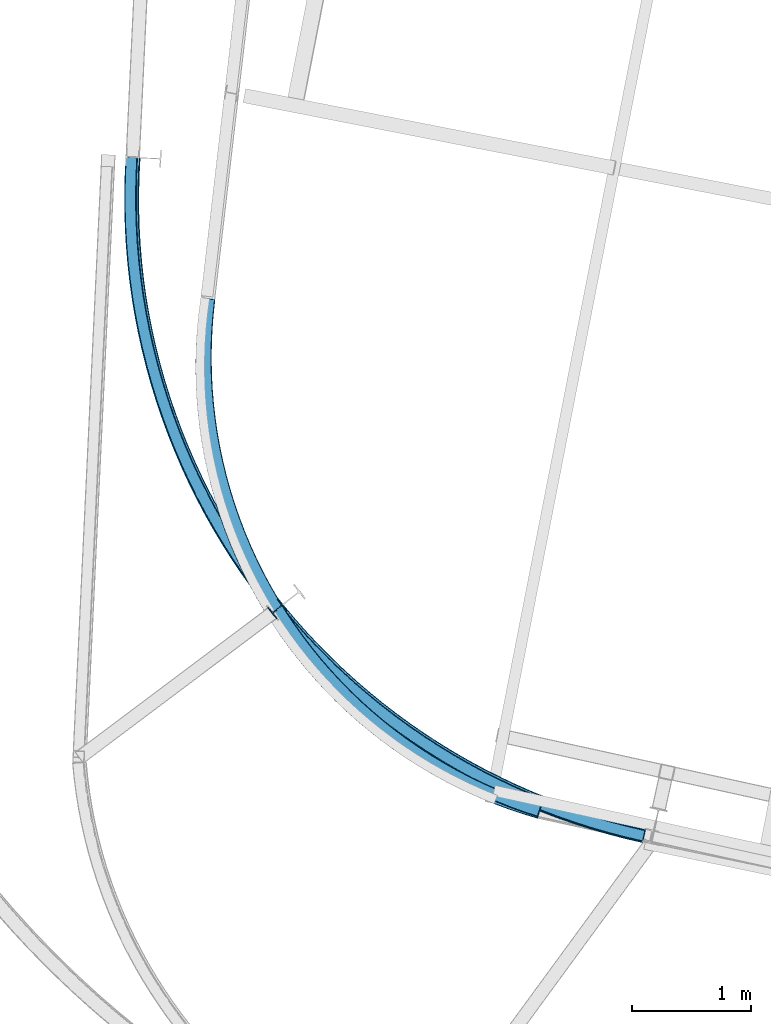
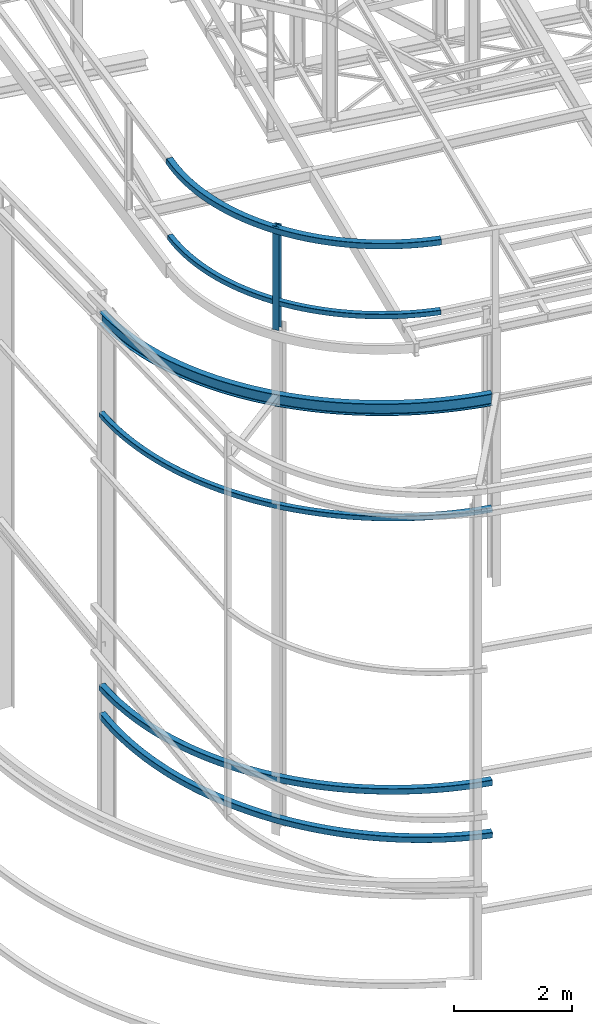
# One storey, part 20 of 215: 7 beams, 7 elements without a shape of their own.
"""IFC2X3 building model written with IfcOpenShell, lengths in millimetres."""

from ifc_helpers import new_model, entity, si_unit, frame, origin_with_axes, origin_2d_with_axis, place, context, subcontext, project, spatial, i_section, extrude, material, type_object, element, aggregate, save


model = new_model("IFC2X3")

# Units and contexts
model_context = context("Model", 3, precision=1e-05, world=origin_with_axes())
body_context = subcontext(model_context, "Body", "Model", "MODEL_VIEW")
ifc_project = project(units=[si_unit("LENGTHUNIT", "METRE", prefix="MILLI"), si_unit("AREAUNIT", "SQUARE_METRE"), si_unit("VOLUMEUNIT", "CUBIC_METRE"), si_unit("MASSUNIT", "GRAM", prefix="KILO"), si_unit("TIMEUNIT", "SECOND"), si_unit("PLANEANGLEUNIT", "RADIAN"), si_unit("SOLIDANGLEUNIT", "STERADIAN"), si_unit("THERMODYNAMICTEMPERATUREUNIT", "DEGREE_CELSIUS"), si_unit("LUMINOUSINTENSITYUNIT", "LUMEN")], contexts=[model_context])

# Site, building, storey
site_placement = place(None, origin_with_axes())
site = spatial("IfcSite", under=ifc_project, at=site_placement, CompositionType="ELEMENT")
building_placement = place(site_placement, origin_with_axes())
building = spatial("IfcBuilding", under=site, at=building_placement, Name="Undefined", CompositionType="ELEMENT")
storey_placement = place(building_placement, origin_with_axes())
storey = spatial("IfcBuildingStorey", under=building, at=storey_placement, Name="Undefined", CompositionType="ELEMENT", Elevation=0.0)

# Assembly, beam
assembly_1_placement = place(storey_placement, origin_with_axes())
assembly_1 = element("IfcElementAssembly", 1, at=assembly_1_placement, inside=storey, Name="Steel Assembly", AssemblyPlace="NOTDEFINED", PredefinedType="RIGID_FRAME")
ifc_material = material(Name="STEEL/S275JR")
beam_type_1 = type_object("IfcBeamType", PredefinedType="NOTDEFINED")
beam_1_placement = place(assembly_1_placement, frame((40664.3456586731, 11067.1046852026, 12701.8503691063), z_axis=(-0.0119994719970859, 0.0186232359954719, 0.999754563756949), x_axis=(-0.541499222857692, 0.840409292779137, -0.0221542829941779)))
beam_1 = element("IfcBeam", 2, at=beam_1_placement, type_object=beam_type_1, material=ifc_material, Name="LISSE", context=body_context, shape_type="SweptSolid", body=[
    entity("IfcRevolvedAreaSolid", entity("IfcRectangleHollowProfileDef", "AREA", None, entity("IfcAxis2Placement2D", entity("IfcCartesianPoint", [0.0, 0.0]), entity("IfcDirection", [1.0, 0.0])), 100.0, 100.0, 4.0, 4.0, 8.0), entity("IfcAxis2Placement3D", entity("IfcCartesianPoint", [5126.01340724275, 7.24332407350426e-12, 0.0]), entity("IfcDirection", [-0.767748194282796, 0.640751675905344, -2.22415249273059e-18]), entity("IfcDirection", [-0.640751675905344, -0.767748194282796, 2.6649779069103e-18])), entity("IfcAxis1Placement", entity("IfcCartesianPoint", [4000.0, 0.0, 0.0]), entity("IfcDirection", [0.0, 1.0, 0.0])), 1.39095386356324),
])
aggregate(assembly_1, [beam_1])

assembly_2_placement = place(storey_placement, origin_with_axes())
assembly_2 = element("IfcElementAssembly", 3, at=assembly_2_placement, inside=storey, Name="Steel Assembly", AssemblyPlace="NOTDEFINED", PredefinedType="RIGID_FRAME")
beam_type_2 = type_object("IfcBeamType", Name="IPE240", PredefinedType="NOTDEFINED")
beam_2_placement = place(assembly_2_placement, frame((41548.2858063852, 10863.7772204885, 10723.9133272284), z_axis=(0.00235029500042555, 0.0493185580090031, 0.998780334182308), x_axis=(-0.602258779734243, 0.797398020648135, -0.0379573299832507)))
beam_2 = element("IfcBeam", 4, at=beam_2_placement, type_object=beam_type_2, material=ifc_material, Name="LISSE", ObjectType="IPE240", context=body_context, shape_type="SweptSolid", body=[
    entity("IfcRevolvedAreaSolid", entity("IfcIShapeProfileDef", "AREA", None, entity("IfcAxis2Placement2D", entity("IfcCartesianPoint", [0.0, 0.0]), entity("IfcDirection", [1.0, 0.0])), 120.0, 240.0, 6.199999809, 9.800000191, 15.0), entity("IfcAxis2Placement3D", entity("IfcCartesianPoint", [7143.91119491563, 2.23068788282046e-13, -1.86856024538631e-12]), entity("IfcDirection", [-0.759395376912215, 0.650629434873918, 9.78401257086074e-18]), entity("IfcDirection", [-0.650629434873919, -0.759395376912215, -7.54715332162265e-19])), entity("IfcAxis1Placement", entity("IfcCartesianPoint", [5490.0, 0.0, 0.0]), entity("IfcDirection", [0.0, 1.0, 0.0])), 1.41682601182093),
])
aggregate(assembly_2, [beam_2])

assembly_3_placement = place(storey_placement, origin_with_axes())
assembly_3 = element("IfcElementAssembly", 5, at=assembly_3_placement, inside=storey, Name="Steel Assembly", AssemblyPlace="NOTDEFINED", PredefinedType="RIGID_FRAME")
beam_type_3 = type_object("IfcBeamType", PredefinedType="NOTDEFINED")
beam_3_placement = place(assembly_3_placement, frame((40669.8931472017, 11061.5428651157, 14159.9969771667), z_axis=(0.0, 0.0, 1.0), x_axis=(-0.542954167697268, 0.83976233053178, -1.00000001200779e-09)))
beam_3 = element("IfcBeam", 6, at=beam_3_placement, type_object=beam_type_3, material=ifc_material, Name="LISSE", context=body_context, shape_type="SweptSolid", body=[
    entity("IfcRevolvedAreaSolid", entity("IfcRectangleHollowProfileDef", "AREA", None, entity("IfcAxis2Placement2D", entity("IfcCartesianPoint", [0.0, 0.0]), entity("IfcDirection", [1.0, 0.0])), 120.0, 120.0, 4.0, 4.0, 8.0), entity("IfcAxis2Placement3D", entity("IfcCartesianPoint", [5143.69815585088, -4.17614925502269e-13, 8.50953478268922e-21]), entity("IfcDirection", [-0.750259274572787, 0.661143721831732, -1.24119985262942e-24]), entity("IfcDirection", [-0.661143721831732, -0.750259274572787, -1.09377053762072e-24])), entity("IfcAxis1Placement", entity("IfcCartesianPoint", [3890.0, 0.0, 0.0]), entity("IfcDirection", [0.0, 1.0, 0.0])), 1.44468434868468),
])
aggregate(assembly_3, [beam_3])

assembly_4_placement = place(storey_placement, origin_with_axes())
assembly_4 = element("IfcElementAssembly", 7, at=assembly_4_placement, inside=storey, Name="Steel Assembly", AssemblyPlace="NOTDEFINED", PredefinedType="RIGID_FRAME")
beam_type_4 = type_object("IfcBeamType", PredefinedType="NOTDEFINED")
beam_4_placement = place(assembly_4_placement, frame((41549.6854446579, 10865.6760779255, 1746.6583310553), z_axis=(0.042577657020065, -0.0540475550254673, 0.997630194470101), x_axis=(-0.601179827996966, 0.796147470995982, 0.0687896709996528)))
beam_4 = element("IfcBeam", 8, at=beam_4_placement, type_object=beam_type_4, material=ifc_material, Name="LISSE", context=body_context, shape_type="SweptSolid", body=[
    entity("IfcRevolvedAreaSolid", entity("IfcRectangleHollowProfileDef", "AREA", None, entity("IfcAxis2Placement2D", entity("IfcCartesianPoint", [0.0, 0.0]), entity("IfcDirection", [1.0, 0.0])), 120.0, 120.0, 5.0, 5.0, 10.0), entity("IfcAxis2Placement3D", entity("IfcCartesianPoint", [7156.63756700625, -7.08030832302859e-15, -9.93182975723462e-14]), entity("IfcDirection", [-0.758400798139634, 0.651788485155396, 1.27862709229998e-17]), entity("IfcDirection", [-0.651788485155396, -0.758400798139634, 6.41415095509866e-18])), entity("IfcAxis1Placement", entity("IfcCartesianPoint", [5490.0, 0.0, 0.0]), entity("IfcDirection", [0.0, 1.0, 0.0])), 1.41988057230864),
])
aggregate(assembly_4, [beam_4])

assembly_5_placement = place(storey_placement, origin_with_axes())
assembly_5 = element("IfcElementAssembly", 9, at=assembly_5_placement, inside=storey, Name="Steel Assembly", AssemblyPlace="NOTDEFINED", PredefinedType="RIGID_FRAME")
beam_5_placement = place(assembly_5_placement, frame((41547.1986223909, 10868.9646470391, 2823.77477282032), z_axis=(2.91090000125356e-05, 2.19800000068886e-05, 0.999999999334773), x_axis=(-0.602607292666343, 0.798037875558135, 0.0)))
beam_5 = element("IfcBeam", 10, at=beam_5_placement, type_object=beam_type_4, material=ifc_material, Name="LISSE", context=body_context, shape_type="SweptSolid", body=[
    entity("IfcRevolvedAreaSolid", entity("IfcRectangleHollowProfileDef", "AREA", None, entity("IfcAxis2Placement2D", entity("IfcCartesianPoint", [0.0, 0.0]), entity("IfcDirection", [1.0, 0.0])), 120.0, 120.0, 5.0, 5.0, 10.0), entity("IfcAxis2Placement3D", entity("IfcCartesianPoint", [7139.68481635229, -7.92664247168095e-13, 2.41901930898467e-17]), entity("IfcDirection", [-0.759724993520056, 0.65024451879347, -6.98027665097288e-21]), entity("IfcDirection", [-0.65024451879347, -0.759724993520056, 2.94498267815403e-21])), entity("IfcAxis1Placement", entity("IfcCartesianPoint", [5490.0, 0.0, 0.0]), entity("IfcDirection", [0.0, 1.0, 0.0])), 1.415812488259),
])
aggregate(assembly_5, [beam_5])

assembly_6_placement = place(storey_placement, origin_with_axes())
assembly_6 = element("IfcElementAssembly", 11, at=assembly_6_placement, inside=storey, Name="Steel Assembly", AssemblyPlace="NOTDEFINED", PredefinedType="RIGID_FRAME")
beam_type_5 = type_object("IfcBeamType", PredefinedType="NOTDEFINED")
beam_6_placement = place(assembly_6_placement, frame((41545.0538758844, 10859.1970488262, 8448.58497796907), z_axis=(2.91090000125356e-05, 2.19800000068886e-05, 0.999999999334773), x_axis=(-0.602607292666343, 0.798037875558135, 0.0)))
beam_6 = element("IfcBeam", 12, at=beam_6_placement, type_object=beam_type_5, material=ifc_material, Name="LISSE", context=body_context, shape_type="SweptSolid", body=[
    entity("IfcRevolvedAreaSolid", entity("IfcRectangleHollowProfileDef", "AREA", None, entity("IfcAxis2Placement2D", entity("IfcCartesianPoint", [0.0, 0.0]), entity("IfcDirection", [1.0, 0.0])), 100.0, 100.0, 5.0, 5.0, 10.0), entity("IfcAxis2Placement3D", entity("IfcCartesianPoint", [7152.68975808485, -1.19116212861395e-12, 2.4234255546345e-17]), entity("IfcDirection", [-0.759724993520056, 0.65024451879347, -6.98027665097288e-21]), entity("IfcDirection", [-0.65024451879347, -0.759724993520056, 2.94498267815403e-21])), entity("IfcAxis1Placement", entity("IfcCartesianPoint", [5500.0, 0.0, 0.0]), entity("IfcDirection", [0.0, 1.0, 0.0])), 1.41581250054973),
])
aggregate(assembly_6, [beam_6])

assembly_7_placement = place(storey_placement, origin_with_axes())
assembly_7 = element("IfcElementAssembly", 13, at=assembly_7_placement, inside=storey, Name="Steel Assembly", AssemblyPlace="NOTDEFINED", PredefinedType="RIGID_FRAME")
beam_type_6 = type_object("IfcBeamType", Name="HEA120", PredefinedType="NOTDEFINED")
beam_7_placement = place(assembly_7_placement, frame((38461.5821831007, 12766.527813759, 14219.9969944513), z_axis=(0.784786213805784, 0.619766567846623, 0.0), x_axis=(0.0, 0.0, -1.0)))
beam_7 = element("IfcBeam", 14, at=beam_7_placement, type_object=beam_type_6, material=ifc_material, ObjectType="HEA120", context=body_context, shape_type="SweptSolid", body=[
    extrude(i_section(OverallWidth=120.0, OverallDepth=114.0, WebThickness=5.0, FlangeThickness=8.0, FilletRadius=12.0, at=origin_2d_with_axis()), frame((2130.28828822983, -1.81898940354586e-12, -7.27595761418343e-12), z_axis=(-1.0, 0.0, 0.0), x_axis=(-6.93889390390723e-18, -1.0, -3.46944695195361e-18)), (0.0, 0.0, 1.0), 2130.3),
])
aggregate(assembly_7, [beam_7])

save(model, "model.ifc")
